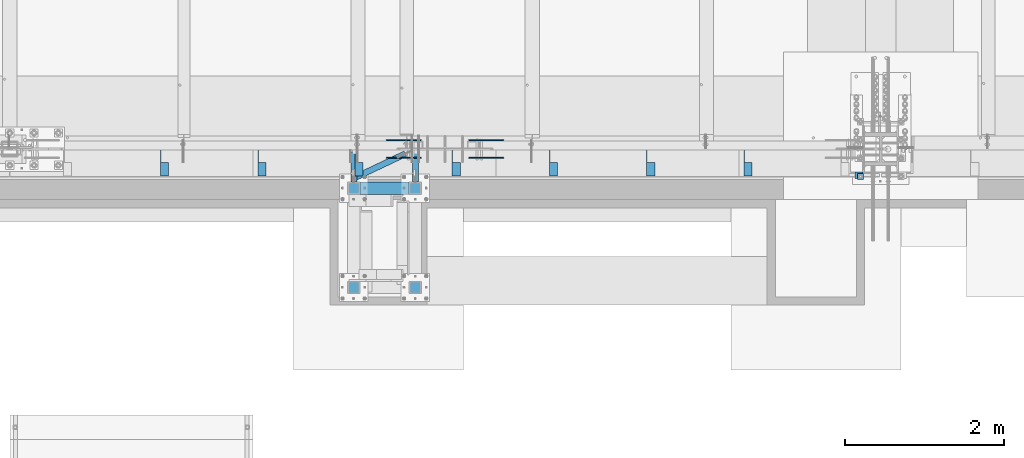
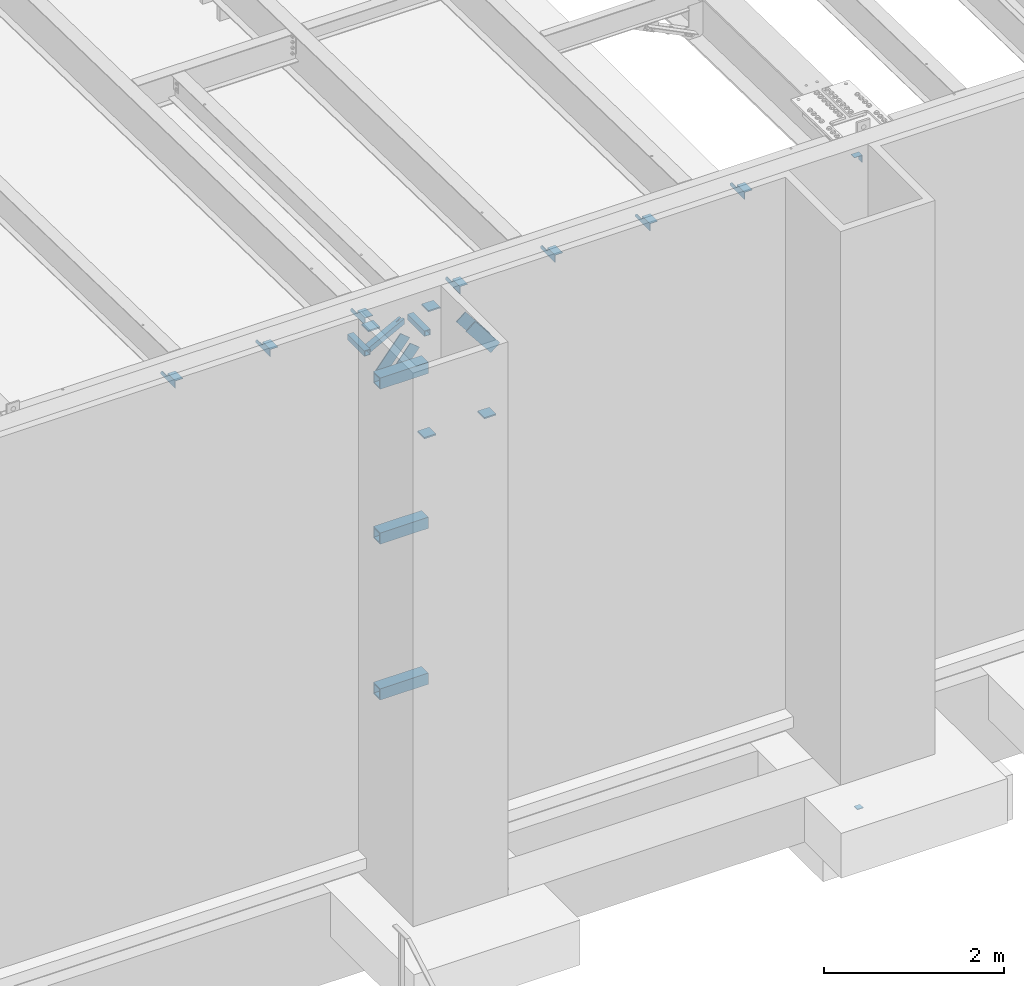
# One storey, part 1288 of 1763: 19 beams, 4 members, 9 elements without a shape of their own.
"""IFC2X3 building model written with IfcOpenShell, lengths in millimetres."""

from ifc_helpers import new_model, si_unit, frame, origin_with_axes, place, context, subcontext, project, spatial, faceted_brep, material, type_object, element, aggregate, save


model = new_model("IFC2X3")

# Units and contexts
model_context = context("Model", 3, precision=1e-05, world=origin_with_axes())
body_context = subcontext(model_context, "Body", "Model", "MODEL_VIEW")
ifc_project = project(units=[si_unit("LENGTHUNIT", "METRE", prefix="MILLI"), si_unit("AREAUNIT", "SQUARE_METRE"), si_unit("VOLUMEUNIT", "CUBIC_METRE"), si_unit("MASSUNIT", "GRAM", prefix="KILO"), si_unit("TIMEUNIT", "SECOND"), si_unit("PLANEANGLEUNIT", "RADIAN"), si_unit("SOLIDANGLEUNIT", "STERADIAN"), si_unit("THERMODYNAMICTEMPERATUREUNIT", "DEGREE_CELSIUS"), si_unit("LUMINOUSINTENSITYUNIT", "LUMEN")], contexts=[model_context])

# Site, building, storey
site_placement = place(None, origin_with_axes())
site = spatial("IfcSite", under=ifc_project, at=site_placement, CompositionType="ELEMENT")
building_placement = place(site_placement, origin_with_axes())
building = spatial("IfcBuilding", under=site, at=building_placement, Name="Undefined", CompositionType="ELEMENT")
storey_placement = place(building_placement, origin_with_axes())
storey = spatial("IfcBuildingStorey", under=building, at=storey_placement, Name="Undefined", CompositionType="ELEMENT", Elevation=0.0)

# Assembly, beam
assembly_1_placement = place(storey_placement, origin_with_axes())
assembly_1 = element("IfcElementAssembly", 1, at=assembly_1_placement, inside=storey, Name="COLUMN", AssemblyPlace="NOTDEFINED", PredefinedType="RIGID_FRAME")
ifc_material_1 = material(Name="STEEL/A36")
beam_type_1 = type_object("IfcBeamType", Name="L4X4X1/4", PredefinedType="NOTDEFINED")
beam_1_placement = place(assembly_1_placement, frame((-24300.8872728616, -14082.7123340176, 12153.8999998665), z_axis=(0.0, 0.0, -1.0), x_axis=(0.0, 1.0, 0.0)))
beam_1 = element("IfcBeam", 2, at=beam_1_placement, type_object=beam_type_1, material=ifc_material_1, Name="BRACE", ObjectType="L4X4X1/4", context=body_context, shape_type="Brep", body=[
    faceted_brep([(-3.63797880709171e-11, 50.8000000000011, -50.8000000000538), (-1.96450855582952e-10, 50.8000000000393, 50.7999999999374), (76.2000000000007, 50.7999999999993, 50.7999999999993), (76.2000000000007, 50.7999999999993, -50.7999999999993), (-1.81898940354586e-10, 44.4500000000371, 50.7999999999374), (76.2000000000007, 44.4500000000007, 50.7999999999993), (-2.18278728425503e-11, 44.4500000000007, -44.450000000048), (76.2000000000007, 44.4500000000007, -44.4500000000007), (1.96450855582952e-10, -50.8000000000338, -44.4499999999534), (76.2000000000007, -50.7999999999993, -44.4500000000007), (2.11002770811319e-10, -50.8000000000357, -50.799999999952), (76.2000000000007, -50.7999999999993, -50.7999999999993)], [[[0, 1, 2, 3]], [[1, 4, 5, 2]], [[4, 6, 7, 5]], [[6, 8, 9, 7]], [[8, 10, 11, 9]], [[10, 0, 3, 11]], [[5, 7, 9, 11, 3, 2]], [[10, 8, 6, 4, 1, 0]]]),
])
aggregate(assembly_1, [beam_1])

# Assembly, beams
assembly_2_placement = place(storey_placement, origin_with_axes())
assembly_2 = element("IfcElementAssembly", 3, at=assembly_2_placement, inside=storey, Name="BEAM", AssemblyPlace="NOTDEFINED", PredefinedType="RIGID_FRAME")
beam_2_placement = place(assembly_2_placement, frame((-25692.4055562795, -13727.9060686172, 12153.8999999997), z_axis=(0.0, 0.0, -1.0), x_axis=(0.0, -1.0, 0.0)))
beam_2 = element("IfcBeam", 4, at=beam_2_placement, type_object=beam_type_1, material=ifc_material_1, Name="BRACE", ObjectType="L4X4X1/4", context=body_context, shape_type="Brep", body=[
    faceted_brep([(156.368567097667, 44.4500000000007, -6.34999980941575), (156.368567097667, 50.7999999999993, -6.34999980941575), (156.368568386746, 50.7999999999993, -50.7999999999993), (156.368568386746, -50.7999999999993, -50.7999999999993), (156.368568202592, -50.7999999999993, -44.4500000000007), (156.368568202592, 44.4500000000007, -44.4500000000007), (31.7499984742426, 44.4500000000007, -6.35000000027321), (31.7499984742426, 50.7999999999993, -6.35000038323415), (-1.81898940354586e-10, 44.4500000000371, 50.7999999999374), (-1.96450855582952e-10, 50.8000000000393, 50.7999999999374), (0.0, 50.7999999999993, 25.3999999997268), (0.0, 44.4500000000007, 25.3999999997268), (324.643737794, 44.4500000000007, 50.7999999999993), (324.643737794, 50.7999999999993, 50.7999999999993), (324.643737794, 44.4500000000007, -44.4500000000007), (324.643737794, -50.7999999999993, -44.4500000000007), (324.643737794, -50.7999999999993, -50.7999999999993), (324.643737794, 50.7999999999993, -50.7999999999993)], [[[0, 1, 2, 3, 4, 5]], [[1, 0, 6, 7]], [[8, 9, 10, 11]], [[9, 8, 12, 13]], [[12, 14, 15, 16, 17, 13]], [[15, 14, 5, 4]], [[16, 15, 4, 3]], [[17, 16, 3, 2]], [[9, 13, 17, 2, 1, 7, 10]], [[6, 11, 10, 7]], [[0, 5, 14, 12, 8, 11, 6]]]),
])
beam_3_placement = place(assembly_2_placement, frame((-26911.6055562795, -13727.9060686172, 12153.8999999997), z_axis=(0.0, 0.0, -1.0), x_axis=(0.0, -1.0, 0.0)))
beam_3 = element("IfcBeam", 5, at=beam_3_placement, type_object=beam_type_1, material=ifc_material_1, Name="BRACE", ObjectType="L4X4X1/4", context=body_context, shape_type="Brep", body=[
    faceted_brep([(156.368567097667, 44.4500000000007, -6.34999980941575), (156.368567097667, 50.7999999999993, -6.34999980941575), (156.368568386746, 50.7999999999993, -50.7999999999993), (156.368568386746, -50.7999999999993, -50.7999999999993), (156.368568202592, -50.7999999999993, -44.4500000000007), (156.368568202592, 44.4500000000007, -44.4500000000007), (31.7499984742426, 44.4500000000007, -6.35000000027321), (31.7499984742426, 50.7999999999993, -6.35000038323415), (-1.81898940354586e-10, 44.4500000000371, 50.7999999999374), (-1.96450855582952e-10, 50.8000000000393, 50.7999999999374), (0.0, 50.7999999999993, 25.3999999997268), (0.0, 44.4500000000007, 25.3999999997268), (324.643737794, 44.4500000000007, 50.7999999999993), (324.643737794, 50.7999999999993, 50.7999999999993), (324.643737794, 44.4500000000007, -44.4500000000007), (324.643737794, -50.7999999999993, -44.4500000000007), (324.643737794, -50.7999999999993, -50.7999999999993), (324.643737794, 50.7999999999993, -50.7999999999993)], [[[0, 1, 2, 3, 4, 5]], [[1, 0, 6, 7]], [[8, 9, 10, 11]], [[9, 8, 12, 13]], [[12, 14, 15, 16, 17, 13]], [[15, 14, 5, 4]], [[16, 15, 4, 3]], [[17, 16, 3, 2]], [[9, 13, 17, 2, 1, 7, 10]], [[6, 11, 10, 7]], [[0, 5, 14, 12, 8, 11, 6]]]),
])
beam_4_placement = place(assembly_2_placement, frame((-28130.8055562795, -13727.9060686172, 12153.8999999997), z_axis=(0.0, 0.0, -1.0), x_axis=(0.0, -1.0, 0.0)))
beam_4 = element("IfcBeam", 6, at=beam_4_placement, type_object=beam_type_1, material=ifc_material_1, Name="BRACE", ObjectType="L4X4X1/4", context=body_context, shape_type="Brep", body=[
    faceted_brep([(156.368567097667, 44.4500000000007, -6.34999980941575), (156.368567097667, 50.7999999999993, -6.34999980941575), (156.368568386746, 50.7999999999993, -50.7999999999993), (156.368568386746, -50.7999999999993, -50.7999999999993), (156.368568202592, -50.7999999999993, -44.4500000000007), (156.368568202592, 44.4500000000007, -44.4500000000007), (31.7499984742426, 44.4500000000007, -6.35000000027321), (31.7499984742426, 50.7999999999993, -6.35000038323415), (-1.81898940354586e-10, 44.4500000000371, 50.7999999999374), (-1.96450855582952e-10, 50.8000000000393, 50.7999999999374), (0.0, 50.7999999999993, 25.3999999997268), (0.0, 44.4500000000007, 25.3999999997268), (324.643737794, 44.4500000000007, 50.7999999999993), (324.643737794, 50.7999999999993, 50.7999999999993), (324.643737794, 44.4500000000007, -44.4500000000007), (324.643737794, -50.7999999999993, -44.4500000000007), (324.643737794, -50.7999999999993, -50.7999999999993), (324.643737794, 50.7999999999993, -50.7999999999993)], [[[0, 1, 2, 3, 4, 5]], [[1, 0, 6, 7]], [[8, 9, 10, 11]], [[9, 8, 12, 13]], [[12, 14, 15, 16, 17, 13]], [[15, 14, 5, 4]], [[16, 15, 4, 3]], [[17, 16, 3, 2]], [[9, 13, 17, 2, 1, 7, 10]], [[6, 11, 10, 7]], [[0, 5, 14, 12, 8, 11, 6]]]),
])
beam_5_placement = place(assembly_2_placement, frame((-29350.0055562795, -13727.9060686172, 12153.8999999997), z_axis=(0.0, 0.0, -1.0), x_axis=(0.0, -1.0, 0.0)))
beam_5 = element("IfcBeam", 7, at=beam_5_placement, type_object=beam_type_1, material=ifc_material_1, Name="BRACE", ObjectType="L4X4X1/4", context=body_context, shape_type="Brep", body=[
    faceted_brep([(156.368567097667, 44.4500000000007, -6.34999980941575), (156.368567097667, 50.7999999999993, -6.34999980941575), (156.368568386746, 50.7999999999993, -50.7999999999993), (156.368568386746, -50.7999999999993, -50.7999999999993), (156.368568202592, -50.7999999999993, -44.4500000000007), (156.368568202592, 44.4500000000007, -44.4500000000007), (31.7499984742426, 44.4500000000007, -6.35000000027321), (31.7499984742426, 50.7999999999993, -6.35000038323415), (-1.81898940354586e-10, 44.4500000000371, 50.7999999999374), (-1.96450855582952e-10, 50.8000000000393, 50.7999999999374), (0.0, 50.7999999999993, 25.3999999997268), (0.0, 44.4500000000007, 25.3999999997268), (324.643737794, 44.4500000000007, 50.7999999999993), (324.643737794, 50.7999999999993, 50.7999999999993), (324.643737794, 44.4500000000007, -44.4500000000007), (324.643737794, -50.7999999999993, -44.4500000000007), (324.643737794, -50.7999999999993, -50.7999999999993), (324.643737794, 50.7999999999993, -50.7999999999993)], [[[0, 1, 2, 3, 4, 5]], [[1, 0, 6, 7]], [[8, 9, 10, 11]], [[9, 8, 12, 13]], [[12, 14, 15, 16, 17, 13]], [[15, 14, 5, 4]], [[16, 15, 4, 3]], [[17, 16, 3, 2]], [[9, 13, 17, 2, 1, 7, 10]], [[6, 11, 10, 7]], [[0, 5, 14, 12, 8, 11, 6]]]),
])
beam_6_placement = place(assembly_2_placement, frame((-30569.2055562795, -13727.9060686172, 12153.8999999997), z_axis=(0.0, 0.0, -1.0), x_axis=(0.0, -1.0, 0.0)))
beam_6 = element("IfcBeam", 8, at=beam_6_placement, type_object=beam_type_1, material=ifc_material_1, Name="BRACE", ObjectType="L4X4X1/4", context=body_context, shape_type="Brep", body=[
    faceted_brep([(156.368567097667, 44.4500000000007, -6.34999980941575), (156.368567097667, 50.7999999999993, -6.34999980941575), (156.368568386746, 50.7999999999993, -50.7999999999993), (156.368568386746, -50.7999999999993, -50.7999999999993), (156.368568202592, -50.7999999999993, -44.4500000000007), (156.368568202592, 44.4500000000007, -44.4500000000007), (31.7499984742426, 44.4500000000007, -6.35000000027321), (31.7499984742426, 50.7999999999993, -6.35000038323415), (-1.81898940354586e-10, 44.4500000000371, 50.7999999999374), (-1.96450855582952e-10, 50.8000000000393, 50.7999999999374), (0.0, 50.7999999999993, 25.3999999997268), (0.0, 44.4500000000007, 25.3999999997268), (324.643737794, 44.4500000000007, 50.7999999999993), (324.643737794, 50.7999999999993, 50.7999999999993), (324.643737794, 44.4500000000007, -44.4500000000007), (324.643737794, -50.7999999999993, -44.4500000000007), (324.643737794, -50.7999999999993, -50.7999999999993), (324.643737794, 50.7999999999993, -50.7999999999993)], [[[0, 1, 2, 3, 4, 5]], [[1, 0, 6, 7]], [[8, 9, 10, 11]], [[9, 8, 12, 13]], [[12, 14, 15, 16, 17, 13]], [[15, 14, 5, 4]], [[16, 15, 4, 3]], [[17, 16, 3, 2]], [[9, 13, 17, 2, 1, 7, 10]], [[6, 11, 10, 7]], [[0, 5, 14, 12, 8, 11, 6]]]),
])
beam_7_placement = place(assembly_2_placement, frame((-31788.4055562795, -13727.9060686171, 12153.8999999997), z_axis=(0.0, 0.0, -1.0), x_axis=(0.0, -1.0, 0.0)))
beam_7 = element("IfcBeam", 9, at=beam_7_placement, type_object=beam_type_1, material=ifc_material_1, Name="BRACE", ObjectType="L4X4X1/4", context=body_context, shape_type="Brep", body=[
    faceted_brep([(156.368567097667, 44.4500000000007, -6.34999980941575), (156.368567097667, 50.7999999999993, -6.34999980941575), (156.368568386746, 50.7999999999993, -50.7999999999993), (156.368568386746, -50.7999999999993, -50.7999999999993), (156.368568202592, -50.7999999999993, -44.4500000000007), (156.368568202592, 44.4500000000007, -44.4500000000007), (31.7499984742426, 44.4500000000007, -6.35000000027321), (31.7499984742426, 50.7999999999993, -6.35000038323415), (-1.81898940354586e-10, 44.4500000000371, 50.7999999999374), (-1.96450855582952e-10, 50.8000000000393, 50.7999999999374), (0.0, 50.7999999999993, 25.3999999997268), (0.0, 44.4500000000007, 25.3999999997268), (324.643737794, 44.4500000000007, 50.7999999999993), (324.643737794, 50.7999999999993, 50.7999999999993), (324.643737794, 44.4500000000007, -44.4500000000007), (324.643737794, -50.7999999999993, -44.4500000000007), (324.643737794, -50.7999999999993, -50.7999999999993), (324.643737794, 50.7999999999993, -50.7999999999993)], [[[0, 1, 2, 3, 4, 5]], [[1, 0, 6, 7]], [[8, 9, 10, 11]], [[9, 8, 12, 13]], [[12, 14, 15, 16, 17, 13]], [[15, 14, 5, 4]], [[16, 15, 4, 3]], [[17, 16, 3, 2]], [[9, 13, 17, 2, 1, 7, 10]], [[6, 11, 10, 7]], [[0, 5, 14, 12, 8, 11, 6]]]),
])
beam_8_placement = place(assembly_2_placement, frame((-33007.6055562795, -13727.9060686171, 12153.8999999997), z_axis=(0.0, 0.0, -1.0), x_axis=(0.0, -1.0, 0.0)))
beam_8 = element("IfcBeam", 10, at=beam_8_placement, type_object=beam_type_1, material=ifc_material_1, Name="BRACE", ObjectType="L4X4X1/4", context=body_context, shape_type="Brep", body=[
    faceted_brep([(156.368567097667, 44.4500000000007, -6.34999980941575), (156.368567097667, 50.7999999999993, -6.34999980941575), (156.368568386746, 50.7999999999993, -50.7999999999993), (156.368568386746, -50.7999999999993, -50.7999999999993), (156.368568202592, -50.7999999999993, -44.4500000000007), (156.368568202592, 44.4500000000007, -44.4500000000007), (31.7499984742426, 44.4500000000007, -6.35000000027321), (31.7499984742426, 50.7999999999993, -6.35000038323415), (-1.81898940354586e-10, 44.4500000000371, 50.7999999999374), (-1.96450855582952e-10, 50.8000000000393, 50.7999999999374), (0.0, 50.7999999999993, 25.3999999997268), (0.0, 44.4500000000007, 25.3999999997268), (324.643737794, 44.4500000000007, 50.7999999999993), (324.643737794, 50.7999999999993, 50.7999999999993), (324.643737794, 44.4500000000007, -44.4500000000007), (324.643737794, -50.7999999999993, -44.4500000000007), (324.643737794, -50.7999999999993, -50.7999999999993), (324.643737794, 50.7999999999993, -50.7999999999993)], [[[0, 1, 2, 3, 4, 5]], [[1, 0, 6, 7]], [[8, 9, 10, 11]], [[9, 8, 12, 13]], [[12, 14, 15, 16, 17, 13]], [[15, 14, 5, 4]], [[16, 15, 4, 3]], [[17, 16, 3, 2]], [[9, 13, 17, 2, 1, 7, 10]], [[6, 11, 10, 7]], [[0, 5, 14, 12, 8, 11, 6]]]),
])
aggregate(assembly_2, [beam_2, beam_3, beam_4, beam_5, beam_6, beam_7, beam_8])

# Assembly, beam
assembly_3_placement = place(storey_placement, origin_with_axes())
assembly_3 = element("IfcElementAssembly", 11, at=assembly_3_placement, inside=storey, Name="BEAM", AssemblyPlace="NOTDEFINED", PredefinedType="RIGID_FRAME")
ifc_material_2 = material()
beam_type_2 = type_object("IfcBeamType", Name="HSS3X3X1/4", PredefinedType="NOTDEFINED")
beam_9_placement = place(assembly_3_placement, frame((-30635.0132880874, -14081.1242675026, 11785.6), z_axis=(0.0, 0.0, 1.0), x_axis=(0.903892997071089, 0.427758635033642, 0.0)))
beam_9 = element("IfcBeam", 12, at=beam_9_placement, type_object=beam_type_2, material=ifc_material_2, Name="BEAM", ObjectType="HSS3X3X1/4", context=body_context, shape_type="Brep", body=[
    faceted_brep([(715.543417779016, 6.34431196991693, 38.1000000000004), (607.593105585183, 6.33738595850457, 38.1000000000004), (607.593105585183, 6.33738595850275, 31.75), (715.543417779016, 6.34431196991693, 31.75), (607.593920407679, -6.36261401531726, 38.1000000000004), (607.593920407679, -6.36261401531726, 31.75), (715.543417778994, -6.35568805618266, 38.1000000000004), (715.543417778994, -6.35568805618266, 31.75), (715.543417779016, 6.34431196991693, -31.75), (607.593105585183, 6.33738595850457, -31.75), (607.593105585183, 6.33738595850457, -38.1000000000004), (715.543417779016, 6.34431196991693, -38.1000000000004), (607.593920407671, -6.36261401531726, -31.75), (607.593920407671, -6.36261401531544, -38.1000000000004), (715.543417778994, -6.35568805618266, -31.75), (715.543417778994, -6.35568805618266, -38.1000000000004), (57.1765513156497, 31.7500000000274, 31.75), (57.1765513156497, 31.7500000000274, -31.75), (715.543417779059, 31.7500000007714, -31.75), (715.543417779059, 31.7500000007714, 31.75), (715.54341777895, -31.7499999991522, 31.75), (27.1255734098886, -31.7499999999308, 31.75), (27.1255734098886, -31.7499999999308, -31.75), (715.54341777895, -31.7499999991522, -31.75), (24.1204756193183, -38.0999999999257, -38.1000000000004), (24.1204756193183, -38.0999999999257, 38.1000000000004), (60.18164910622, 38.1000000000241, 38.1000000000004), (60.18164910622, 38.1000000000241, -38.1000000000004), (715.543417779067, 38.1000000007626, 38.1000000000004), (715.543417779067, 38.1000000007626, -38.1000000000004), (715.543417778943, -38.0999999991471, -38.1000000000004), (715.543417778943, -38.0999999991471, 38.1000000000004)], [[[0, 1, 2, 3]], [[4, 5, 2, 1]], [[6, 7, 5, 4]], [[8, 9, 10, 11]], [[12, 13, 10, 9]], [[14, 15, 13, 12]], [[16, 17, 18, 19]], [[20, 21, 16, 19, 3, 2, 5, 7]], [[22, 21, 20, 23]], [[9, 8, 18, 17, 22, 23, 14, 12]], [[24, 25, 26, 27], [16, 21, 22, 17]], [[27, 26, 28, 29]], [[19, 18, 8, 11, 29, 28, 0, 3]], [[30, 24, 27, 29, 11, 10, 13, 15]], [[25, 24, 30, 31]], [[1, 0, 28, 26, 25, 31, 6, 4]], [[31, 30, 15, 14, 23, 20, 7, 6]]]),
])
aggregate(assembly_3, [beam_9])

assembly_4_placement = place(storey_placement, origin_with_axes())
assembly_4 = element("IfcElementAssembly", 13, at=assembly_4_placement, inside=storey, Name="BEAM", AssemblyPlace="NOTDEFINED", PredefinedType="RIGID_FRAME")
beam_10_placement = place(assembly_4_placement, frame((-29863.4886408952, -14208.1242675037, 11785.6), z_axis=(0.0, 0.0, 1.0), x_axis=(2.77799999886291e-06, 0.999999999996141, 0.0)))
beam_10 = element("IfcBeam", 14, at=beam_10_placement, type_object=beam_type_2, material=ifc_material_2, Name="BEAM", ObjectType="HSS3X3X1/4", context=body_context, shape_type="Brep", body=[
    faceted_brep([(76.1999117843825, 31.7499999999636, -31.75), (76.2000881873828, -31.7500000000509, -31.75), (454.818287090084, -31.750000000291, -31.75), (454.818110687085, 31.7499999997235, -31.75), (76.2000881873828, -31.7500000000509, 31.75), (454.818287090084, -31.750000000291, 31.75), (76.1999117843825, 31.7499999999636, 31.75), (454.818110687085, 31.7499999997235, 31.75), (76.1998941440834, 38.0999999999658, -38.1000000000004), (76.1998941440834, 38.0999999999658, 38.1000000000004), (454.818093046784, 38.0999999997221, 38.1000000000004), (454.818093046784, 38.0999999997221, -38.1000000000004), (76.2001058276837, -38.1000000000495, 38.1000000000004), (454.818304730385, -38.1000000002932, 38.1000000000004), (76.2001058276837, -38.1000000000495, -38.1000000000004), (454.818304730385, -38.1000000002932, -38.1000000000004)], [[[0, 1, 2, 3]], [[1, 4, 5, 2]], [[4, 6, 7, 5]], [[6, 0, 3, 7]], [[8, 9, 10, 11]], [[9, 12, 13, 10]], [[12, 14, 15, 13]], [[14, 8, 11, 15]], [[13, 15, 11, 10], [5, 7, 3, 2]], [[14, 12, 9, 8], [6, 4, 1, 0]]]),
])
aggregate(assembly_4, [beam_10])

assembly_5_placement = place(storey_placement, origin_with_axes())
assembly_5 = element("IfcElementAssembly", 15, at=assembly_5_placement, inside=storey, Name="BEAM", AssemblyPlace="NOTDEFINED", PredefinedType="RIGID_FRAME")
beam_11_placement = place(assembly_5_placement, frame((-30635.0136408935, -14208.1242675021, 11785.6), z_axis=(0.0, 0.0, 1.0), x_axis=(2.77799999886291e-06, 0.999999999996141, 0.0)))
beam_11 = element("IfcBeam", 16, at=beam_11_placement, type_object=beam_type_2, material=ifc_material_2, Name="BEAM", ObjectType="HSS3X3X1/4", context=body_context, shape_type="Brep", body=[
    faceted_brep([(76.1999117843825, 31.7499999999636, -31.75), (76.2000881873828, -31.7500000000509, -31.75), (454.818287090084, -31.750000000291, -31.75), (454.818110687085, 31.7499999997235, -31.75), (76.2000881873828, -31.7500000000509, 31.75), (454.818287090084, -31.750000000291, 31.75), (76.1999117843825, 31.7499999999636, 31.75), (454.818110687085, 31.7499999997235, 31.75), (76.1998941440834, 38.0999999999658, -38.1000000000004), (76.1998941440834, 38.0999999999658, 38.1000000000004), (454.818093046784, 38.0999999997221, 38.1000000000004), (454.818093046784, 38.0999999997221, -38.1000000000004), (76.2001058276837, -38.1000000000495, 38.1000000000004), (454.818304730385, -38.1000000002932, 38.1000000000004), (76.2001058276837, -38.1000000000495, -38.1000000000004), (454.818304730385, -38.1000000002932, -38.1000000000004)], [[[0, 1, 2, 3]], [[1, 4, 5, 2]], [[4, 6, 7, 5]], [[6, 0, 3, 7]], [[8, 9, 10, 11]], [[9, 12, 13, 10]], [[12, 14, 15, 13]], [[14, 8, 11, 15]], [[13, 15, 11, 10], [5, 7, 3, 2]], [[14, 12, 9, 8], [6, 4, 1, 0]]]),
])
aggregate(assembly_5, [beam_11])

# Assembly, beams
assembly_6_placement = place(storey_placement, origin_with_axes())
assembly_6 = element("IfcElementAssembly", 17, at=assembly_6_placement, inside=storey, Name="FRAME", AssemblyPlace="NOTDEFINED", PredefinedType="RIGID_FRAME")
beam_type_3 = type_object("IfcBeamType", PredefinedType="NOTDEFINED")
beam_12_placement = place(assembly_6_placement, frame((-29863.4870783858, -14284.3242675181, 12195.175), z_axis=(1.0, 0.0, 0.0), x_axis=(0.0, 1.0, 0.0)))
beam_12 = element("IfcBeam", 18, at=beam_12_placement, type_object=beam_type_3, material=ifc_material_1, Name="PLATE", context=body_context, shape_type="Brep", body=[
    faceted_brep([(0.0, 9.52499999999964, -76.1999999999971), (0.0, 9.52499999999964, 76.1999999999971), (152.400000000001, 9.52499999999964, 76.1999999999971), (152.400000000001, 9.52499999999964, -76.1999999999971), (0.0, -9.52499999999964, 76.1999999999971), (152.400000000001, -9.52499999999964, 76.1999999999971), (0.0, -9.52499999999964, -76.1999999999971), (152.400000000001, -9.52499999999964, -76.1999999999971)], [[[0, 1, 2, 3]], [[1, 4, 5, 2]], [[4, 6, 7, 5]], [[6, 0, 3, 7]], [[5, 7, 3, 2]], [[6, 4, 1, 0]]]),
])
beam_13_placement = place(assembly_6_placement, frame((-30635.0122736984, -14284.3242675181, 12195.175), z_axis=(1.0, 0.0, 0.0), x_axis=(0.0, 1.0, 0.0)))
beam_13 = element("IfcBeam", 19, at=beam_13_placement, type_object=beam_type_3, material=ifc_material_1, Name="PLATE", context=body_context, shape_type="Brep", body=[
    faceted_brep([(0.0, 9.52499999999964, -76.1999999999971), (0.0, 9.52499999999964, 76.1999999999971), (152.400000000001, 9.52499999999964, 76.1999999999971), (152.400000000001, 9.52499999999964, -76.1999999999971), (0.0, -9.52499999999964, 76.1999999999971), (152.400000000001, -9.52499999999964, 76.1999999999971), (0.0, -9.52499999999964, -76.1999999999971), (152.400000000001, -9.52499999999964, -76.1999999999971)], [[[0, 1, 2, 3]], [[1, 4, 5, 2]], [[4, 6, 7, 5]], [[6, 0, 3, 7]], [[5, 7, 3, 2]], [[6, 4, 1, 0]]]),
])
beam_14_placement = place(assembly_6_placement, frame((-29863.4870783858, -15528.9242675181, 11496.675), z_axis=(1.0, 0.0, 0.0), x_axis=(0.0, 1.0, 0.0)))
beam_14 = element("IfcBeam", 20, at=beam_14_placement, type_object=beam_type_3, material=ifc_material_1, Name="PLATE", context=body_context, shape_type="Brep", body=[
    faceted_brep([(0.0, 9.52499999999964, -76.1999999999971), (0.0, 9.52499999999964, 76.1999999999971), (152.400000000001, 9.52499999999964, 76.1999999999971), (152.400000000001, 9.52499999999964, -76.1999999999971), (0.0, -9.52499999999964, 76.1999999999971), (152.400000000001, -9.52499999999964, 76.1999999999971), (0.0, -9.52499999999964, -76.1999999999971), (152.400000000001, -9.52499999999964, -76.1999999999971)], [[[0, 1, 2, 3]], [[1, 4, 5, 2]], [[4, 6, 7, 5]], [[6, 0, 3, 7]], [[5, 7, 3, 2]], [[6, 4, 1, 0]]]),
])
beam_15_placement = place(assembly_6_placement, frame((-30635.0122736984, -15528.9242675181, 11496.675), z_axis=(1.0, 0.0, 0.0), x_axis=(0.0, 1.0, 0.0)))
beam_15 = element("IfcBeam", 21, at=beam_15_placement, type_object=beam_type_3, material=ifc_material_1, Name="PLATE", context=body_context, shape_type="Brep", body=[
    faceted_brep([(0.0, 9.52499999999964, -76.1999999999971), (0.0, 9.52499999999964, 76.1999999999971), (152.400000000001, 9.52499999999964, 76.1999999999971), (152.400000000001, 9.52499999999964, -76.1999999999971), (0.0, -9.52499999999964, 76.1999999999971), (152.400000000001, -9.52499999999964, 76.1999999999971), (0.0, -9.52499999999964, -76.1999999999971), (152.400000000001, -9.52499999999964, -76.1999999999971)], [[[0, 1, 2, 3]], [[1, 4, 5, 2]], [[4, 6, 7, 5]], [[6, 0, 3, 7]], [[5, 7, 3, 2]], [[6, 4, 1, 0]]]),
])
beam_type_4 = type_object("IfcBeamType", Name="HSS6X6X5/8", PredefinedType="NOTDEFINED")
beam_16_placement = place(assembly_6_placement, frame((-30635.0122248702, -14208.1242675181, 11430.0), z_axis=(0.0, 0.0, 1.0), x_axis=(1.0, 0.0, 0.0)))
beam_16 = element("IfcBeam", 22, at=beam_16_placement, type_object=beam_type_4, material=ifc_material_2, Name="BEAM", ObjectType="HSS6X6X5/8", context=body_context, shape_type="Brep", body=[
    faceted_brep([(76.1999511718459, 60.3250000000007, -60.3250000000007), (76.1999511718459, -60.3250000000007, -60.3250000000007), (695.325146484363, -60.3250000000007, -60.3250000000007), (695.325146484363, 60.3250000000007, -60.3250000000007), (76.1999511718459, -60.3250000000007, 60.3250000000007), (695.325146484363, -60.3250000000007, 60.3250000000007), (76.1999511718459, 60.3250000000007, 60.3250000000007), (695.325146484363, 60.3250000000007, 60.3250000000007), (76.1999511718459, 76.2000000000007, -76.2000000000007), (76.1999511718459, 76.2000000000007, 76.2000000000007), (695.325146484363, 76.2000000000007, 76.2000000000007), (695.325146484363, 76.2000000000007, -76.2000000000007), (76.1999511718459, -76.2000000000007, 76.2000000000007), (695.325146484363, -76.2000000000007, 76.2000000000007), (76.1999511718459, -76.2000000000007, -76.2000000000007), (695.325146484363, -76.2000000000007, -76.2000000000007)], [[[0, 1, 2, 3]], [[1, 4, 5, 2]], [[4, 6, 7, 5]], [[6, 0, 3, 7]], [[8, 9, 10, 11]], [[9, 12, 13, 10]], [[12, 14, 15, 13]], [[14, 8, 11, 15]], [[13, 15, 11, 10], [5, 7, 3, 2]], [[14, 12, 9, 8], [6, 4, 1, 0]]]),
])
beam_17_placement = place(assembly_6_placement, frame((-30635.0122248702, -14208.1242675181, 9325.96736125847), z_axis=(0.0, 0.0, 1.0), x_axis=(1.0, 0.0, 0.0)))
beam_17 = element("IfcBeam", 23, at=beam_17_placement, type_object=beam_type_4, material=ifc_material_2, Name="BEAM", ObjectType="HSS6X6X5/8", context=body_context, shape_type="Brep", body=[
    faceted_brep([(76.1999511718459, 60.3250000000007, -60.3250000000007), (76.1999511718459, -60.3250000000007, -60.3250000000007), (695.325146484363, -60.3250000000007, -60.3250000000007), (695.325146484363, 60.3250000000007, -60.3250000000007), (76.1999511718459, -60.3250000000007, 60.3250000000007), (695.325146484363, -60.3250000000007, 60.3250000000007), (76.1999511718459, 60.3250000000007, 60.3250000000007), (695.325146484363, 60.3250000000007, 60.3250000000007), (76.1999511718459, 76.2000000000007, -76.2000000000007), (76.1999511718459, 76.2000000000007, 76.2000000000007), (695.325146484363, 76.2000000000007, 76.2000000000007), (695.325146484363, 76.2000000000007, -76.2000000000007), (76.1999511718459, -76.2000000000007, 76.2000000000007), (695.325146484363, -76.2000000000007, 76.2000000000007), (76.1999511718459, -76.2000000000007, -76.2000000000007), (695.325146484363, -76.2000000000007, -76.2000000000007)], [[[0, 1, 2, 3]], [[1, 4, 5, 2]], [[4, 6, 7, 5]], [[6, 0, 3, 7]], [[8, 9, 10, 11]], [[9, 12, 13, 10]], [[12, 14, 15, 13]], [[14, 8, 11, 15]], [[13, 15, 11, 10], [5, 7, 3, 2]], [[14, 12, 9, 8], [6, 4, 1, 0]]]),
])
beam_18_placement = place(assembly_6_placement, frame((-30635.012127214, -14208.1242675181, 7209.43305003711), z_axis=(0.0, 0.0, 1.0), x_axis=(1.0, 0.0, 0.0)))
beam_18 = element("IfcBeam", 24, at=beam_18_placement, type_object=beam_type_4, material=ifc_material_2, Name="BEAM", ObjectType="HSS6X6X5/8", context=body_context, shape_type="Brep", body=[
    faceted_brep([(76.1998535156017, 60.3250000000007, -60.3249999999998), (76.1998535156017, -60.3250000000007, -60.3249999999998), (695.325048828119, -60.3250000000007, -60.3249999999998), (695.325048828119, 60.3250000000007, -60.3249999999998), (76.1998535156017, -60.3250000000007, 60.3249999999998), (695.325048828119, -60.3250000000007, 60.3249999999998), (76.1998535156017, 60.3250000000007, 60.3249999999998), (695.325048828119, 60.3250000000007, 60.3249999999998), (76.1998535156017, 76.2000000000007, -76.1999999999998), (76.1998535156017, 76.2000000000007, 76.1999999999998), (695.325048828119, 76.2000000000007, 76.1999999999998), (695.325048828119, 76.2000000000007, -76.1999999999998), (76.1998535156017, -76.2000000000007, 76.1999999999998), (695.325048828119, -76.2000000000007, 76.1999999999998), (76.1998535156017, -76.2000000000007, -76.1999999999998), (695.325048828119, -76.2000000000007, -76.1999999999998)], [[[0, 1, 2, 3]], [[1, 4, 5, 2]], [[4, 6, 7, 5]], [[6, 0, 3, 7]], [[8, 9, 10, 11]], [[9, 12, 13, 10]], [[12, 14, 15, 13]], [[14, 8, 11, 15]], [[13, 15, 11, 10], [5, 7, 3, 2]], [[14, 12, 9, 8], [6, 4, 1, 0]]]),
])
aggregate(assembly_6, [beam_16, beam_17, beam_18, beam_12, beam_13, beam_14, beam_15])

# Assembly, members
assembly_7_placement = place(storey_placement, origin_with_axes())
assembly_7 = element("IfcElementAssembly", 25, at=assembly_7_placement, inside=storey, Name="V. BRACE", AssemblyPlace="NOTDEFINED", PredefinedType="RIGID_FRAME")
member_type = type_object("IfcMemberType", PredefinedType="NOTDEFINED")
member_1_placement = place(assembly_7_placement, frame((-29132.9021418545, -13608.05, 11429.9949695153), z_axis=(0.780585099299328, 0.0, 0.625049520239683), x_axis=(0.625049520239684, 0.0, -0.780585099299327)))
member_1 = element("IfcMember", 26, at=member_1_placement, type_object=member_type, material=ifc_material_1, Name="PLATE", context=body_context, shape_type="Brep", body=[
    faceted_brep([(4.36557456851006e-11, 6.35000000000036, -76.2000000000044), (-4.72937244921923e-11, 6.35000000000036, 76.1999999999898), (507.999999999498, 6.35000000000036, 76.1999999995642), (507.999999999589, 6.35000000000036, -76.20000000043), (-4.72937244921923e-11, -6.35000000000036, 76.1999999999898), (507.999999999498, -6.35000000000036, 76.1999999995642), (4.36557456851006e-11, -6.35000000000036, -76.2000000000044), (507.999999999589, -6.35000000000036, -76.20000000043)], [[[0, 1, 2, 3]], [[1, 4, 5, 2]], [[4, 6, 7, 5]], [[6, 0, 3, 7]], [[5, 7, 3, 2]], [[6, 4, 1, 0]]]),
])
member_2_placement = place(assembly_7_placement, frame((-29132.9021418545, -13823.95, 11429.9949695153), z_axis=(0.780585099299328, 0.0, 0.625049520239683), x_axis=(0.625049520239684, 0.0, -0.780585099299327)))
member_2 = element("IfcMember", 27, at=member_2_placement, type_object=member_type, material=ifc_material_1, Name="PLATE", context=body_context, shape_type="Brep", body=[
    faceted_brep([(4.36557456851006e-11, 6.35000000000036, -76.2000000000044), (-4.72937244921923e-11, 6.35000000000036, 76.1999999999898), (507.999999999498, 6.35000000000036, 76.1999999995642), (507.999999999589, 6.35000000000036, -76.20000000043), (-4.72937244921923e-11, -6.35000000000036, 76.1999999999898), (507.999999999498, -6.35000000000036, 76.1999999995642), (4.36557456851006e-11, -6.35000000000036, -76.2000000000044), (507.999999999589, -6.35000000000036, -76.20000000043)], [[[0, 1, 2, 3]], [[1, 4, 5, 2]], [[4, 6, 7, 5]], [[6, 0, 3, 7]], [[5, 7, 3, 2]], [[6, 4, 1, 0]]]),
])
aggregate(assembly_7, [member_1, member_2])

assembly_8_placement = place(storey_placement, origin_with_axes())
assembly_8 = element("IfcElementAssembly", 28, at=assembly_8_placement, inside=storey, Name="V. BRACE", AssemblyPlace="NOTDEFINED", PredefinedType="RIGID_FRAME")
member_3_placement = place(assembly_8_placement, frame((-29849.1460089537, -13823.95, 11429.560613688), z_axis=(-0.777142613013369, 0.0, 0.629324526010828), x_axis=(-0.629324526010829, 0.0, -0.777142613013368)))
member_3 = element("IfcMember", 29, at=member_3_placement, type_object=member_type, material=ifc_material_1, Name="PLATE", context=body_context, shape_type="Brep", body=[
    faceted_brep([(4.36557456851006e-11, 6.35000000000036, -76.2000000000044), (-4.72937244921923e-11, 6.35000000000036, 76.1999999999898), (507.999999999498, 6.35000000000036, 76.1999999995642), (507.999999999589, 6.35000000000036, -76.20000000043), (-4.72937244921923e-11, -6.35000000000036, 76.1999999999898), (507.999999999498, -6.35000000000036, 76.1999999995642), (4.36557456851006e-11, -6.35000000000036, -76.2000000000044), (507.999999999589, -6.35000000000036, -76.20000000043)], [[[0, 1, 2, 3]], [[1, 4, 5, 2]], [[4, 6, 7, 5]], [[6, 0, 3, 7]], [[5, 7, 3, 2]], [[6, 4, 1, 0]]]),
])
member_4_placement = place(assembly_8_placement, frame((-29849.1460089537, -13608.05, 11429.560613688), z_axis=(-0.777142613013369, 0.0, 0.629324526010828), x_axis=(-0.629324526010829, 0.0, -0.777142613013368)))
member_4 = element("IfcMember", 30, at=member_4_placement, type_object=member_type, material=ifc_material_1, Name="PLATE", context=body_context, shape_type="Brep", body=[
    faceted_brep([(4.36557456851006e-11, 6.35000000000036, -76.2000000000044), (-4.72937244921923e-11, 6.35000000000036, 76.1999999999898), (507.999999999498, 6.35000000000036, 76.1999999995642), (507.999999999589, 6.35000000000036, -76.20000000043), (-4.72937244921923e-11, -6.35000000000036, 76.1999999999898), (507.999999999498, -6.35000000000036, 76.1999999995642), (4.36557456851006e-11, -6.35000000000036, -76.2000000000044), (507.999999999589, -6.35000000000036, -76.20000000043)], [[[0, 1, 2, 3]], [[1, 4, 5, 2]], [[4, 6, 7, 5]], [[6, 0, 3, 7]], [[5, 7, 3, 2]], [[6, 4, 1, 0]]]),
])
aggregate(assembly_8, [member_3, member_4])

# Assembly, beam
assembly_9_placement = place(storey_placement, origin_with_axes())
assembly_9 = element("IfcElementAssembly", 31, at=assembly_9_placement, inside=storey, Name="TEMPLATE", AssemblyPlace="NOTDEFINED", PredefinedType="RIGID_FRAME")
beam_type_5 = type_object("IfcBeamType", PredefinedType="NOTDEFINED")
beam_19_placement = place(assembly_9_placement, frame((-24281.8372736984, -14097.0000000001, 3348.0375), z_axis=(1.0, 0.0, 0.0), x_axis=(0.0, 1.0, 0.0)))
beam_19 = element("IfcBeam", 32, at=beam_19_placement, type_object=beam_type_5, material=ifc_material_1, Name="WASHER PLATE", context=body_context, shape_type="Brep", body=[
    faceted_brep([(0.0, 4.76249999999709, -38.1000000000004), (0.0, 4.76249999999709, 38.1000000000004), (76.2000000000007, 4.76249999999982, 38.0999999999985), (76.2000000000007, 4.76249999999982, -38.0999999999985), (0.0, -4.76249999999709, 38.1000000000004), (76.2000000000007, -4.76249999999982, 38.0999999999985), (0.0, -4.76249999999709, -38.1000000000004), (76.2000000000007, -4.76249999999982, -38.0999999999985)], [[[0, 1, 2, 3]], [[1, 4, 5, 2]], [[4, 6, 7, 5]], [[6, 0, 3, 7]], [[5, 7, 3, 2]], [[6, 4, 1, 0]]]),
])
aggregate(assembly_9, [beam_19])

save(model, "model.ifc")
